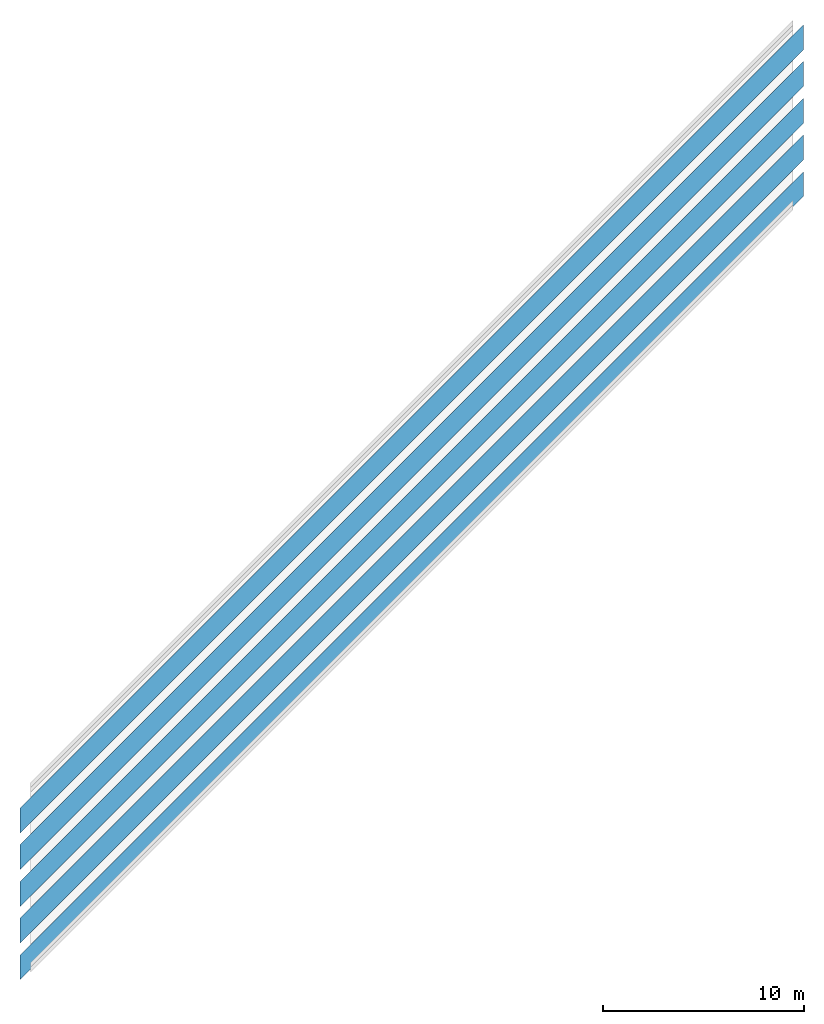
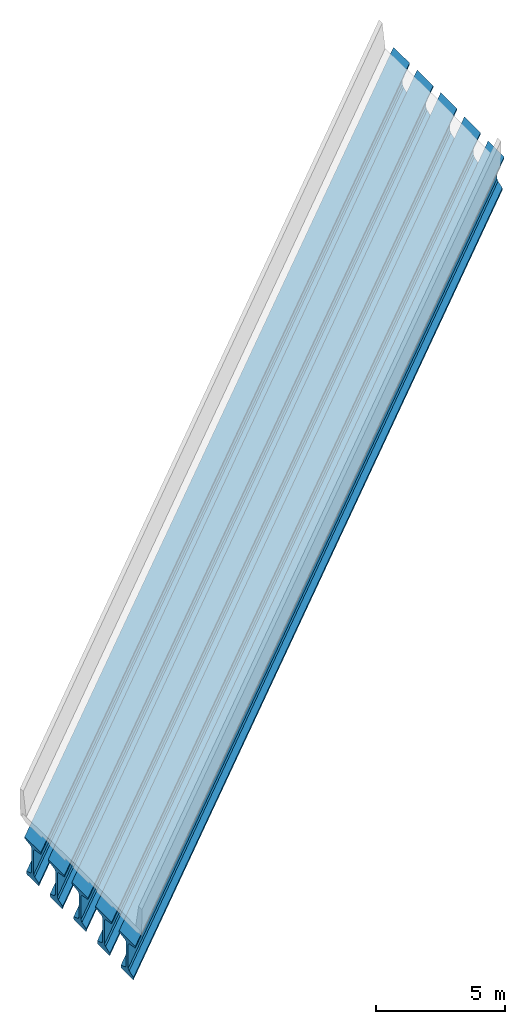
# Not in any storey, part 1 of 3: 5 beams, 5 elements without a shape of their own.
"""IFC4X3_ADD2 model written with IfcOpenShell, lengths in metres."""

from ifc_helpers import new_model, entity, si_unit, direction, origin_with_axes, place, context, project, spatial, material, element, aggregate, save


model = new_model("IFC4X3_ADD2")

# Units and contexts
model_context = context("Model", 3, precision=1e-05, world=origin_with_axes(), true_north=direction((0.0, 1.0)))
ifc_project = project(units=[si_unit("LENGTHUNIT", "METRE"), si_unit("PLANEANGLEUNIT", "RADIAN")], contexts=[model_context])

# Site, bridge, bridge part
site_placement = place(None, origin_with_axes())
site = spatial("IfcSite", under=ifc_project, at=site_placement, CompositionType="ELEMENT")
bridge = spatial("IfcBridge", under=site, CompositionType="COMPLEX", PredefinedType="GIRDER")
bridge_part = spatial("IfcBridgePart", under=bridge, CompositionType="PARTIAL", PredefinedType="SUPERSTRUCTURE", UsageType="LONGITUDINAL")

# Assembly, beam
assembly_1 = element("IfcElementAssembly", 1, inside=bridge_part, Name="Span 1, Girder A", PredefinedType="GIRDER")
ifc_material_1 = material(Name="Precast Segment Concrete")
shared_composite_curve = entity("IfcCompositeCurve", [entity("IfcCurveSegment", "CONTSAMEGRADIENT", entity("IfcAxis2Placement2D", entity("IfcCartesianPoint", [-39.624, 0.0]), entity("IfcDirection", [1.0, 0.0])), entity("IfcLengthMeasure", 0.0), entity("IfcLengthMeasure", 139.624), entity("IfcLine", entity("IfcCartesianPoint", [0.0, 0.0]), entity("IfcVector", entity("IfcDirection", [1.0, 0.0]), 1.0))), entity("IfcCurveSegment", "DISCONTINUOUS", entity("IfcAxis2Placement2D", entity("IfcCartesianPoint", [100.0, 0.0]), entity("IfcDirection", [1.0, 0.0])), entity("IfcLengthMeasure", 0.0), entity("IfcLengthMeasure", 0.0), entity("IfcLine", entity("IfcCartesianPoint", [0.0, 0.0]), entity("IfcVector", entity("IfcDirection", [1.0, 0.0]), 1.0)))], False)
shared_gradient_curve = entity("IfcGradientCurve", [entity("IfcCurveSegment", "CONTSAMEGRADIENT", entity("IfcAxis2Placement2D", entity("IfcCartesianPoint", [0.0, 0.0]), entity("IfcDirection", [1.0, 0.0])), entity("IfcLengthMeasure", 0.0), entity("IfcLengthMeasure", 139.624), entity("IfcLine", entity("IfcCartesianPoint", [0.0, 0.0]), entity("IfcVector", entity("IfcDirection", [1.0, 0.0]), 1.0))), entity("IfcCurveSegment", "DISCONTINUOUS", entity("IfcAxis2Placement2D", entity("IfcCartesianPoint", [0.0, 0.0]), entity("IfcDirection", [1.0, 0.0])), entity("IfcLengthMeasure", 0.0), entity("IfcLengthMeasure", 0.0), entity("IfcLine", entity("IfcCartesianPoint", [0.0, 0.0]), entity("IfcVector", entity("IfcDirection", [1.0, 0.0]), 1.0)))], False, shared_composite_curve)
linear_placement_1 = entity("IfcLinearPlacement", None, entity("IfcAxis2PlacementLinear", entity("IfcPointByDistanceExpression", entity("IfcLengthMeasure", 39.9288), 0.0, 0.0, 0.0, shared_gradient_curve), entity("IfcDirection", [0.0, 0.0, 1.0]), entity("IfcDirection", [1.0, 0.0, 0.0])))
ifc_polyline_1 = entity("IfcPolyline", [entity("IfcCartesianPoint", [0.0, 0.0, 0.0]), entity("IfcCartesianPoint", [39.0144, 0.0, 0.0])])
cartesian_point_1 = entity("IfcCartesianPoint", [-3.6576, -0.356435772821333])
cartesian_point_2 = entity("IfcCartesianPoint", [-3.6576, -0.356435772821333])
beam_1 = element("IfcBeam", 2, at=linear_placement_1, material=ifc_material_1, Name="Segment 1", PredefinedType="GIRDER_SEGMENT", context=model_context, shape_type="AdvancedSweptSolid", body=[
    entity("IfcSectionedSolidHorizontal", ifc_polyline_1, [entity("IfcArbitraryClosedProfileDef", "AREA", None, entity("IfcPolyline", [cartesian_point_1, entity("IfcCartesianPoint", [-4.2799, -0.356435772821333]), entity("IfcCartesianPoint", [-4.2799, -0.432635772821333]), entity("IfcCartesianPoint", [-3.8115875, -0.508835772821333]), entity("IfcCartesianPoint", [-3.7353875, -0.585035772821333]), entity("IfcCartesianPoint", [-3.7353875, -1.71216077282133]), entity("IfcCartesianPoint", [-3.8115875, -1.78836077282133]), entity("IfcCartesianPoint", [-4.1449625, -1.90266077282133]), entity("IfcCartesianPoint", [-4.1449625, -2.00743577282133]), entity("IfcCartesianPoint", [-4.1195625, -2.03283577282133]), entity("IfcCartesianPoint", [-3.6576, -2.03283577282133]), entity("IfcCartesianPoint", [-3.1956375, -2.03283577282133]), entity("IfcCartesianPoint", [-3.1702375, -2.00743577282133]), entity("IfcCartesianPoint", [-3.1702375, -1.90266077282133]), entity("IfcCartesianPoint", [-3.5036125, -1.78836077282133]), entity("IfcCartesianPoint", [-3.5798125, -1.71216077282133]), entity("IfcCartesianPoint", [-3.5798125, -0.585035772821333]), entity("IfcCartesianPoint", [-3.5036125, -0.508835772821333]), entity("IfcCartesianPoint", [-3.0353, -0.432635772821333]), entity("IfcCartesianPoint", [-3.0353, -0.356435772821333]), cartesian_point_1])), entity("IfcArbitraryClosedProfileDef", "AREA", None, entity("IfcPolyline", [cartesian_point_2, entity("IfcCartesianPoint", [-4.2799, -0.356435772821333]), entity("IfcCartesianPoint", [-4.2799, -0.432635772821333]), entity("IfcCartesianPoint", [-3.8115875, -0.508835772821333]), entity("IfcCartesianPoint", [-3.7353875, -0.585035772821333]), entity("IfcCartesianPoint", [-3.7353875, -1.71216077282133]), entity("IfcCartesianPoint", [-3.8115875, -1.78836077282133]), entity("IfcCartesianPoint", [-4.1449625, -1.90266077282133]), entity("IfcCartesianPoint", [-4.1449625, -2.00743577282133]), entity("IfcCartesianPoint", [-4.1195625, -2.03283577282133]), entity("IfcCartesianPoint", [-3.6576, -2.03283577282133]), entity("IfcCartesianPoint", [-3.1956375, -2.03283577282133]), entity("IfcCartesianPoint", [-3.1702375, -2.00743577282133]), entity("IfcCartesianPoint", [-3.1702375, -1.90266077282133]), entity("IfcCartesianPoint", [-3.5036125, -1.78836077282133]), entity("IfcCartesianPoint", [-3.5798125, -1.71216077282133]), entity("IfcCartesianPoint", [-3.5798125, -0.585035772821333]), entity("IfcCartesianPoint", [-3.5036125, -0.508835772821333]), entity("IfcCartesianPoint", [-3.0353, -0.432635772821333]), entity("IfcCartesianPoint", [-3.0353, -0.356435772821333]), cartesian_point_2]))], [entity("IfcAxis2PlacementLinear", entity("IfcPointByDistanceExpression", entity("IfcLengthMeasure", 0.0), None, None, None, ifc_polyline_1)), entity("IfcAxis2PlacementLinear", entity("IfcPointByDistanceExpression", entity("IfcLengthMeasure", 39.0144), None, None, None, ifc_polyline_1))]),
])
aggregate(assembly_1, [beam_1])

assembly_2 = element("IfcElementAssembly", 3, inside=bridge_part, Name="Span 1, Girder B", PredefinedType="GIRDER")
ifc_material_2 = material(Name="Precast Segment Concrete")
linear_placement_2 = entity("IfcLinearPlacement", None, entity("IfcAxis2PlacementLinear", entity("IfcPointByDistanceExpression", entity("IfcLengthMeasure", 39.9288), 0.0, 0.0, 0.0, shared_gradient_curve), entity("IfcDirection", [0.0, 0.0, 1.0]), entity("IfcDirection", [1.0, 0.0, 0.0])))
ifc_polyline_2 = entity("IfcPolyline", [entity("IfcCartesianPoint", [0.0, 0.0, 0.0]), entity("IfcCartesianPoint", [39.0144, 0.0, 0.0])])
cartesian_point_3 = entity("IfcCartesianPoint", [-1.8288, -0.319859772821333])
cartesian_point_4 = entity("IfcCartesianPoint", [-1.8288, -0.319859772821333])
beam_2 = element("IfcBeam", 4, at=linear_placement_2, material=ifc_material_2, Name="Segment 1", PredefinedType="GIRDER_SEGMENT", context=model_context, shape_type="AdvancedSweptSolid", body=[
    entity("IfcSectionedSolidHorizontal", ifc_polyline_2, [entity("IfcArbitraryClosedProfileDef", "AREA", None, entity("IfcPolyline", [cartesian_point_3, entity("IfcCartesianPoint", [-2.4511, -0.319859772821333]), entity("IfcCartesianPoint", [-2.4511, -0.396059772821333]), entity("IfcCartesianPoint", [-1.9827875, -0.472259772821333]), entity("IfcCartesianPoint", [-1.9065875, -0.548459772821333]), entity("IfcCartesianPoint", [-1.9065875, -1.67558477282133]), entity("IfcCartesianPoint", [-1.9827875, -1.75178477282133]), entity("IfcCartesianPoint", [-2.3161625, -1.86608477282133]), entity("IfcCartesianPoint", [-2.3161625, -1.97085977282133]), entity("IfcCartesianPoint", [-2.2907625, -1.99625977282133]), entity("IfcCartesianPoint", [-1.8288, -1.99625977282133]), entity("IfcCartesianPoint", [-1.3668375, -1.99625977282133]), entity("IfcCartesianPoint", [-1.3414375, -1.97085977282133]), entity("IfcCartesianPoint", [-1.3414375, -1.86608477282133]), entity("IfcCartesianPoint", [-1.6748125, -1.75178477282133]), entity("IfcCartesianPoint", [-1.7510125, -1.67558477282133]), entity("IfcCartesianPoint", [-1.7510125, -0.548459772821333]), entity("IfcCartesianPoint", [-1.6748125, -0.472259772821333]), entity("IfcCartesianPoint", [-1.2065, -0.396059772821333]), entity("IfcCartesianPoint", [-1.2065, -0.319859772821333]), cartesian_point_3])), entity("IfcArbitraryClosedProfileDef", "AREA", None, entity("IfcPolyline", [cartesian_point_4, entity("IfcCartesianPoint", [-2.4511, -0.319859772821333]), entity("IfcCartesianPoint", [-2.4511, -0.396059772821333]), entity("IfcCartesianPoint", [-1.9827875, -0.472259772821333]), entity("IfcCartesianPoint", [-1.9065875, -0.548459772821333]), entity("IfcCartesianPoint", [-1.9065875, -1.67558477282133]), entity("IfcCartesianPoint", [-1.9827875, -1.75178477282133]), entity("IfcCartesianPoint", [-2.3161625, -1.86608477282133]), entity("IfcCartesianPoint", [-2.3161625, -1.97085977282133]), entity("IfcCartesianPoint", [-2.2907625, -1.99625977282133]), entity("IfcCartesianPoint", [-1.8288, -1.99625977282133]), entity("IfcCartesianPoint", [-1.3668375, -1.99625977282133]), entity("IfcCartesianPoint", [-1.3414375, -1.97085977282133]), entity("IfcCartesianPoint", [-1.3414375, -1.86608477282133]), entity("IfcCartesianPoint", [-1.6748125, -1.75178477282133]), entity("IfcCartesianPoint", [-1.7510125, -1.67558477282133]), entity("IfcCartesianPoint", [-1.7510125, -0.548459772821333]), entity("IfcCartesianPoint", [-1.6748125, -0.472259772821333]), entity("IfcCartesianPoint", [-1.2065, -0.396059772821333]), entity("IfcCartesianPoint", [-1.2065, -0.319859772821333]), cartesian_point_4]))], [entity("IfcAxis2PlacementLinear", entity("IfcPointByDistanceExpression", entity("IfcLengthMeasure", 0.0), None, None, None, ifc_polyline_2)), entity("IfcAxis2PlacementLinear", entity("IfcPointByDistanceExpression", entity("IfcLengthMeasure", 39.0144), None, None, None, ifc_polyline_2))]),
])
aggregate(assembly_2, [beam_2])

assembly_3 = element("IfcElementAssembly", 5, inside=bridge_part, Name="Span 1, Girder C", PredefinedType="GIRDER")
ifc_material_3 = material(Name="Precast Segment Concrete")
linear_placement_3 = entity("IfcLinearPlacement", None, entity("IfcAxis2PlacementLinear", entity("IfcPointByDistanceExpression", entity("IfcLengthMeasure", 39.9288), 0.0, 0.0, 0.0, shared_gradient_curve), entity("IfcDirection", [0.0, 0.0, 1.0]), entity("IfcDirection", [1.0, 0.0, 0.0])))
ifc_polyline_3 = entity("IfcPolyline", [entity("IfcCartesianPoint", [0.0, 0.0, 0.0]), entity("IfcCartesianPoint", [39.0144, 0.0, 0.0])])
cartesian_point_5 = entity("IfcCartesianPoint", [0.0, -0.283283772821333])
cartesian_point_6 = entity("IfcCartesianPoint", [0.0, -0.283283772821333])
beam_3 = element("IfcBeam", 6, at=linear_placement_3, material=ifc_material_3, Name="Segment 1", PredefinedType="GIRDER_SEGMENT", context=model_context, shape_type="AdvancedSweptSolid", body=[
    entity("IfcSectionedSolidHorizontal", ifc_polyline_3, [entity("IfcArbitraryClosedProfileDef", "AREA", None, entity("IfcPolyline", [cartesian_point_5, entity("IfcCartesianPoint", [-0.6223, -0.283283772821333]), entity("IfcCartesianPoint", [-0.6223, -0.359483772821333]), entity("IfcCartesianPoint", [-0.1539875, -0.435683772821333]), entity("IfcCartesianPoint", [-0.0777875, -0.511883772821333]), entity("IfcCartesianPoint", [-0.0777875, -1.63900877282133]), entity("IfcCartesianPoint", [-0.1539875, -1.71520877282133]), entity("IfcCartesianPoint", [-0.4873625, -1.82950877282133]), entity("IfcCartesianPoint", [-0.4873625, -1.93428377282133]), entity("IfcCartesianPoint", [-0.4619625, -1.95968377282133]), entity("IfcCartesianPoint", [0.0, -1.95968377282133]), entity("IfcCartesianPoint", [0.4619625, -1.95968377282133]), entity("IfcCartesianPoint", [0.4873625, -1.93428377282133]), entity("IfcCartesianPoint", [0.4873625, -1.82950877282133]), entity("IfcCartesianPoint", [0.1539875, -1.71520877282133]), entity("IfcCartesianPoint", [0.0777875, -1.63900877282133]), entity("IfcCartesianPoint", [0.0777875, -0.511883772821333]), entity("IfcCartesianPoint", [0.1539875, -0.435683772821333]), entity("IfcCartesianPoint", [0.6223, -0.359483772821333]), entity("IfcCartesianPoint", [0.6223, -0.283283772821333]), cartesian_point_5])), entity("IfcArbitraryClosedProfileDef", "AREA", None, entity("IfcPolyline", [cartesian_point_6, entity("IfcCartesianPoint", [-0.6223, -0.283283772821333]), entity("IfcCartesianPoint", [-0.6223, -0.359483772821333]), entity("IfcCartesianPoint", [-0.1539875, -0.435683772821333]), entity("IfcCartesianPoint", [-0.0777875, -0.511883772821333]), entity("IfcCartesianPoint", [-0.0777875, -1.63900877282133]), entity("IfcCartesianPoint", [-0.1539875, -1.71520877282133]), entity("IfcCartesianPoint", [-0.4873625, -1.82950877282133]), entity("IfcCartesianPoint", [-0.4873625, -1.93428377282133]), entity("IfcCartesianPoint", [-0.4619625, -1.95968377282133]), entity("IfcCartesianPoint", [0.0, -1.95968377282133]), entity("IfcCartesianPoint", [0.4619625, -1.95968377282133]), entity("IfcCartesianPoint", [0.4873625, -1.93428377282133]), entity("IfcCartesianPoint", [0.4873625, -1.82950877282133]), entity("IfcCartesianPoint", [0.1539875, -1.71520877282133]), entity("IfcCartesianPoint", [0.0777875, -1.63900877282133]), entity("IfcCartesianPoint", [0.0777875, -0.511883772821333]), entity("IfcCartesianPoint", [0.1539875, -0.435683772821333]), entity("IfcCartesianPoint", [0.6223, -0.359483772821333]), entity("IfcCartesianPoint", [0.6223, -0.283283772821333]), cartesian_point_6]))], [entity("IfcAxis2PlacementLinear", entity("IfcPointByDistanceExpression", entity("IfcLengthMeasure", 0.0), None, None, None, ifc_polyline_3)), entity("IfcAxis2PlacementLinear", entity("IfcPointByDistanceExpression", entity("IfcLengthMeasure", 39.0144), None, None, None, ifc_polyline_3))]),
])
aggregate(assembly_3, [beam_3])

assembly_4 = element("IfcElementAssembly", 7, inside=bridge_part, Name="Span 1, Girder D", PredefinedType="GIRDER")
ifc_material_4 = material(Name="Precast Segment Concrete")
linear_placement_4 = entity("IfcLinearPlacement", None, entity("IfcAxis2PlacementLinear", entity("IfcPointByDistanceExpression", entity("IfcLengthMeasure", 39.9288), 0.0, 0.0, 0.0, shared_gradient_curve), entity("IfcDirection", [0.0, 0.0, 1.0]), entity("IfcDirection", [1.0, 0.0, 0.0])))
ifc_polyline_4 = entity("IfcPolyline", [entity("IfcCartesianPoint", [0.0, 0.0, 0.0]), entity("IfcCartesianPoint", [39.0144, 0.0, 0.0])])
cartesian_point_7 = entity("IfcCartesianPoint", [1.8288, -0.319859772821333])
cartesian_point_8 = entity("IfcCartesianPoint", [1.8288, -0.319859772821333])
beam_4 = element("IfcBeam", 8, at=linear_placement_4, material=ifc_material_4, Name="Segment 1", PredefinedType="GIRDER_SEGMENT", context=model_context, shape_type="AdvancedSweptSolid", body=[
    entity("IfcSectionedSolidHorizontal", ifc_polyline_4, [entity("IfcArbitraryClosedProfileDef", "AREA", None, entity("IfcPolyline", [cartesian_point_7, entity("IfcCartesianPoint", [1.2065, -0.319859772821333]), entity("IfcCartesianPoint", [1.2065, -0.396059772821333]), entity("IfcCartesianPoint", [1.6748125, -0.472259772821333]), entity("IfcCartesianPoint", [1.7510125, -0.548459772821333]), entity("IfcCartesianPoint", [1.7510125, -1.67558477282133]), entity("IfcCartesianPoint", [1.6748125, -1.75178477282133]), entity("IfcCartesianPoint", [1.3414375, -1.86608477282133]), entity("IfcCartesianPoint", [1.3414375, -1.97085977282133]), entity("IfcCartesianPoint", [1.3668375, -1.99625977282133]), entity("IfcCartesianPoint", [1.8288, -1.99625977282133]), entity("IfcCartesianPoint", [2.2907625, -1.99625977282133]), entity("IfcCartesianPoint", [2.3161625, -1.97085977282133]), entity("IfcCartesianPoint", [2.3161625, -1.86608477282133]), entity("IfcCartesianPoint", [1.9827875, -1.75178477282133]), entity("IfcCartesianPoint", [1.9065875, -1.67558477282133]), entity("IfcCartesianPoint", [1.9065875, -0.548459772821333]), entity("IfcCartesianPoint", [1.9827875, -0.472259772821333]), entity("IfcCartesianPoint", [2.4511, -0.396059772821333]), entity("IfcCartesianPoint", [2.4511, -0.319859772821333]), cartesian_point_7])), entity("IfcArbitraryClosedProfileDef", "AREA", None, entity("IfcPolyline", [cartesian_point_8, entity("IfcCartesianPoint", [1.2065, -0.319859772821333]), entity("IfcCartesianPoint", [1.2065, -0.396059772821333]), entity("IfcCartesianPoint", [1.6748125, -0.472259772821333]), entity("IfcCartesianPoint", [1.7510125, -0.548459772821333]), entity("IfcCartesianPoint", [1.7510125, -1.67558477282133]), entity("IfcCartesianPoint", [1.6748125, -1.75178477282133]), entity("IfcCartesianPoint", [1.3414375, -1.86608477282133]), entity("IfcCartesianPoint", [1.3414375, -1.97085977282133]), entity("IfcCartesianPoint", [1.3668375, -1.99625977282133]), entity("IfcCartesianPoint", [1.8288, -1.99625977282133]), entity("IfcCartesianPoint", [2.2907625, -1.99625977282133]), entity("IfcCartesianPoint", [2.3161625, -1.97085977282133]), entity("IfcCartesianPoint", [2.3161625, -1.86608477282133]), entity("IfcCartesianPoint", [1.9827875, -1.75178477282133]), entity("IfcCartesianPoint", [1.9065875, -1.67558477282133]), entity("IfcCartesianPoint", [1.9065875, -0.548459772821333]), entity("IfcCartesianPoint", [1.9827875, -0.472259772821333]), entity("IfcCartesianPoint", [2.4511, -0.396059772821333]), entity("IfcCartesianPoint", [2.4511, -0.319859772821333]), cartesian_point_8]))], [entity("IfcAxis2PlacementLinear", entity("IfcPointByDistanceExpression", entity("IfcLengthMeasure", 0.0), None, None, None, ifc_polyline_4)), entity("IfcAxis2PlacementLinear", entity("IfcPointByDistanceExpression", entity("IfcLengthMeasure", 39.0144), None, None, None, ifc_polyline_4))]),
])
aggregate(assembly_4, [beam_4])

assembly_5 = element("IfcElementAssembly", 9, inside=bridge_part, Name="Span 1, Girder E", PredefinedType="GIRDER")
ifc_material_5 = material(Name="Precast Segment Concrete")
linear_placement_5 = entity("IfcLinearPlacement", None, entity("IfcAxis2PlacementLinear", entity("IfcPointByDistanceExpression", entity("IfcLengthMeasure", 39.9288), 0.0, 0.0, 0.0, shared_gradient_curve), entity("IfcDirection", [0.0, 0.0, 1.0]), entity("IfcDirection", [1.0, 0.0, 0.0])))
ifc_polyline_5 = entity("IfcPolyline", [entity("IfcCartesianPoint", [0.0, 0.0, 0.0]), entity("IfcCartesianPoint", [39.0144, 0.0, 0.0])])
cartesian_point_9 = entity("IfcCartesianPoint", [3.6576, -0.356435772821333])
cartesian_point_10 = entity("IfcCartesianPoint", [3.6576, -0.356435772821333])
beam_5 = element("IfcBeam", 10, at=linear_placement_5, material=ifc_material_5, Name="Segment 1", PredefinedType="GIRDER_SEGMENT", context=model_context, shape_type="AdvancedSweptSolid", body=[
    entity("IfcSectionedSolidHorizontal", ifc_polyline_5, [entity("IfcArbitraryClosedProfileDef", "AREA", None, entity("IfcPolyline", [cartesian_point_9, entity("IfcCartesianPoint", [3.0353, -0.356435772821333]), entity("IfcCartesianPoint", [3.0353, -0.432635772821333]), entity("IfcCartesianPoint", [3.5036125, -0.508835772821333]), entity("IfcCartesianPoint", [3.5798125, -0.585035772821333]), entity("IfcCartesianPoint", [3.5798125, -1.71216077282133]), entity("IfcCartesianPoint", [3.5036125, -1.78836077282133]), entity("IfcCartesianPoint", [3.1702375, -1.90266077282133]), entity("IfcCartesianPoint", [3.1702375, -2.00743577282133]), entity("IfcCartesianPoint", [3.1956375, -2.03283577282133]), entity("IfcCartesianPoint", [3.6576, -2.03283577282133]), entity("IfcCartesianPoint", [4.1195625, -2.03283577282133]), entity("IfcCartesianPoint", [4.1449625, -2.00743577282133]), entity("IfcCartesianPoint", [4.1449625, -1.90266077282133]), entity("IfcCartesianPoint", [3.8115875, -1.78836077282133]), entity("IfcCartesianPoint", [3.7353875, -1.71216077282133]), entity("IfcCartesianPoint", [3.7353875, -0.585035772821333]), entity("IfcCartesianPoint", [3.8115875, -0.508835772821333]), entity("IfcCartesianPoint", [4.2799, -0.432635772821333]), entity("IfcCartesianPoint", [4.2799, -0.356435772821333]), cartesian_point_9])), entity("IfcArbitraryClosedProfileDef", "AREA", None, entity("IfcPolyline", [cartesian_point_10, entity("IfcCartesianPoint", [3.0353, -0.356435772821333]), entity("IfcCartesianPoint", [3.0353, -0.432635772821333]), entity("IfcCartesianPoint", [3.5036125, -0.508835772821333]), entity("IfcCartesianPoint", [3.5798125, -0.585035772821333]), entity("IfcCartesianPoint", [3.5798125, -1.71216077282133]), entity("IfcCartesianPoint", [3.5036125, -1.78836077282133]), entity("IfcCartesianPoint", [3.1702375, -1.90266077282133]), entity("IfcCartesianPoint", [3.1702375, -2.00743577282133]), entity("IfcCartesianPoint", [3.1956375, -2.03283577282133]), entity("IfcCartesianPoint", [3.6576, -2.03283577282133]), entity("IfcCartesianPoint", [4.1195625, -2.03283577282133]), entity("IfcCartesianPoint", [4.1449625, -2.00743577282133]), entity("IfcCartesianPoint", [4.1449625, -1.90266077282133]), entity("IfcCartesianPoint", [3.8115875, -1.78836077282133]), entity("IfcCartesianPoint", [3.7353875, -1.71216077282133]), entity("IfcCartesianPoint", [3.7353875, -0.585035772821333]), entity("IfcCartesianPoint", [3.8115875, -0.508835772821333]), entity("IfcCartesianPoint", [4.2799, -0.432635772821333]), entity("IfcCartesianPoint", [4.2799, -0.356435772821333]), cartesian_point_10]))], [entity("IfcAxis2PlacementLinear", entity("IfcPointByDistanceExpression", entity("IfcLengthMeasure", 0.0), None, None, None, ifc_polyline_5)), entity("IfcAxis2PlacementLinear", entity("IfcPointByDistanceExpression", entity("IfcLengthMeasure", 39.0144), None, None, None, ifc_polyline_5))]),
])
aggregate(assembly_5, [beam_5])

save(model, "model.ifc")
